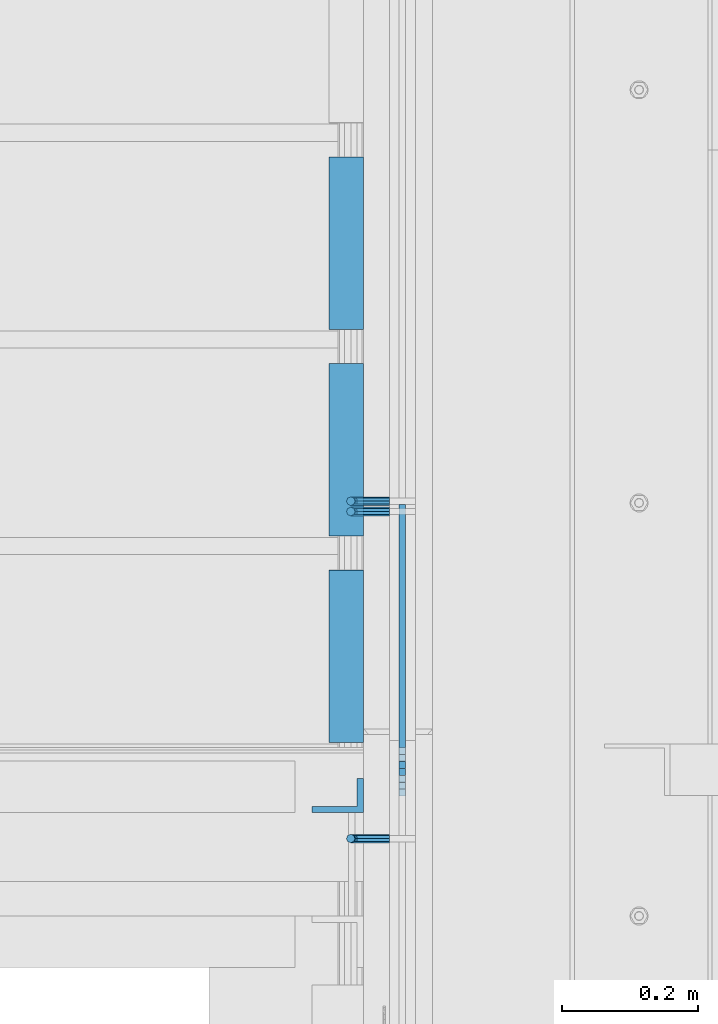
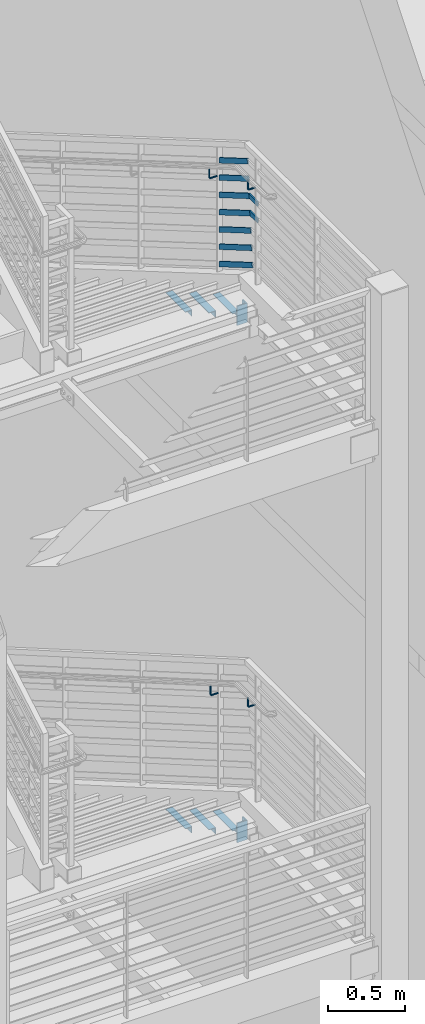
# One storey, part 867 of 1179: 14 beams, 7 members, 6 elements without a shape of their own.
"""IFC2X3 building model written with IfcOpenShell, lengths in millimetres."""

from ifc_helpers import new_model, si_unit, frame, origin_with_axes, place, context, subcontext, project, spatial, faceted_brep, material, type_object, element, aggregate, save


model = new_model("IFC2X3")

# Units and contexts
model_context = context("Model", 3, precision=1e-05, world=origin_with_axes())
body_context = subcontext(model_context, "Body", "Model", "MODEL_VIEW")
ifc_project = project(units=[si_unit("LENGTHUNIT", "METRE", prefix="MILLI"), si_unit("AREAUNIT", "SQUARE_METRE"), si_unit("VOLUMEUNIT", "CUBIC_METRE"), si_unit("MASSUNIT", "GRAM", prefix="KILO"), si_unit("TIMEUNIT", "SECOND"), si_unit("PLANEANGLEUNIT", "RADIAN"), si_unit("SOLIDANGLEUNIT", "STERADIAN"), si_unit("THERMODYNAMICTEMPERATUREUNIT", "DEGREE_CELSIUS"), si_unit("LUMINOUSINTENSITYUNIT", "LUMEN")], contexts=[model_context])

# Site, building, storey
site_placement = place(None, origin_with_axes())
site = spatial("IfcSite", under=ifc_project, at=site_placement, CompositionType="ELEMENT")
building_placement = place(site_placement, origin_with_axes())
building = spatial("IfcBuilding", under=site, at=building_placement, Name="Undefined", CompositionType="ELEMENT")
storey_placement = place(building_placement, origin_with_axes())
storey = spatial("IfcBuildingStorey", under=building, at=storey_placement, Name="Undefined", CompositionType="ELEMENT", Elevation=0.0)

# Assembly, beams
assembly_1_placement = place(storey_placement, origin_with_axes())
assembly_1 = element("IfcElementAssembly", 1, at=assembly_1_placement, inside=storey, Name="STRINGER", AssemblyPlace="NOTDEFINED", PredefinedType="RIGID_FRAME")
ifc_material = material(Name="STEEL/A36")
beam_type_1 = type_object("IfcBeamType", Name="L2X2X3/16", PredefinedType="NOTDEFINED")
beam_1_placement = place(assembly_1_placement, frame((-330.199999978706, 32145.9356228095, 5934.07499988955), z_axis=(-1.0, 0.0, 0.0), x_axis=(0.0, -1.0, 0.0)))
beam_1 = element("IfcBeam", 2, at=beam_1_placement, type_object=beam_type_1, material=ifc_material, Name="ANGLE", ObjectType="L2X2X3/16", context=body_context, shape_type="Brep", body=[
    faceted_brep([(0.0, 25.3999999999996, -25.4000000000015), (0.0, 25.3999999999996, 25.4000000000015), (254.0, 25.3999999999996, 25.4000000000001), (254.0, 25.3999999999996, -25.4000000000001), (0.0, 20.6374999999998, 25.4000000000015), (254.0, 20.6374999999998, 25.4000000000001), (0.0, 20.6374999999998, -20.6374999999971), (254.0, 20.6374999999998, -20.6374999999998), (0.0, -25.3999999999996, -20.6374999999971), (254.0, -25.3999999999996, -20.6374999999998), (0.0, -25.3999999999996, -25.4000000000015), (254.0, -25.3999999999996, -25.4000000000001)], [[[0, 1, 2, 3]], [[1, 4, 5, 2]], [[4, 6, 7, 5]], [[6, 8, 9, 7]], [[8, 10, 11, 9]], [[10, 0, 3, 11]], [[5, 7, 9, 11, 3, 2]], [[10, 8, 6, 4, 1, 0]]]),
])
beam_2_placement = place(assembly_1_placement, frame((-330.199999980762, 32450.7356227456, 5756.27499977985), z_axis=(-1.0, 0.0, 0.0), x_axis=(0.0, -1.0, 0.0)))
beam_2 = element("IfcBeam", 3, at=beam_2_placement, type_object=beam_type_1, material=ifc_material, Name="ANGLE", ObjectType="L2X2X3/16", context=body_context, shape_type="Brep", body=[
    faceted_brep([(0.0, 25.3999999999996, -25.4000000000015), (0.0, 25.3999999999996, 25.4000000000015), (254.0, 25.3999999999996, 25.4000000000001), (254.0, 25.3999999999996, -25.4000000000001), (0.0, 20.6374999999998, 25.4000000000015), (254.0, 20.6374999999998, 25.4000000000001), (0.0, 20.6374999999998, -20.6374999999971), (254.0, 20.6374999999998, -20.6374999999998), (0.0, -25.3999999999996, -20.6374999999971), (254.0, -25.3999999999996, -20.6374999999998), (0.0, -25.3999999999996, -25.4000000000015), (254.0, -25.3999999999996, -25.4000000000001)], [[[0, 1, 2, 3]], [[1, 4, 5, 2]], [[4, 6, 7, 5]], [[6, 8, 9, 7]], [[8, 10, 11, 9]], [[10, 0, 3, 11]], [[5, 7, 9, 11, 3, 2]], [[10, 8, 6, 4, 1, 0]]]),
])
beam_3_placement = place(assembly_1_placement, frame((-330.199999982818, 32755.5356226816, 5578.47499967015), z_axis=(-1.0, 0.0, 0.0), x_axis=(0.0, -1.0, 0.0)))
beam_3 = element("IfcBeam", 4, at=beam_3_placement, type_object=beam_type_1, material=ifc_material, Name="ANGLE", ObjectType="L2X2X3/16", context=body_context, shape_type="Brep", body=[
    faceted_brep([(0.0, 25.3999999999996, -25.4000000000015), (0.0, 25.3999999999996, 25.4000000000015), (254.0, 25.3999999999996, 25.4000000000001), (254.0, 25.3999999999996, -25.4000000000001), (0.0, 20.6374999999998, 25.4000000000015), (254.0, 20.6374999999998, 25.4000000000001), (0.0, 20.6374999999998, -20.6374999999971), (254.0, 20.6374999999998, -20.6374999999998), (0.0, -25.3999999999996, -20.6374999999971), (254.0, -25.3999999999996, -20.6374999999998), (0.0, -25.3999999999996, -25.4000000000015), (254.0, -25.3999999999996, -25.4000000000001)], [[[0, 1, 2, 3]], [[1, 4, 5, 2]], [[4, 6, 7, 5]], [[6, 8, 9, 7]], [[8, 10, 11, 9]], [[10, 0, 3, 11]], [[5, 7, 9, 11, 3, 2]], [[10, 8, 6, 4, 1, 0]]]),
])
aggregate(assembly_1, [beam_1, beam_2, beam_3])

assembly_2_placement = place(storey_placement, origin_with_axes())
assembly_2 = element("IfcElementAssembly", 5, at=assembly_2_placement, inside=storey, Name="STRINGER", AssemblyPlace="NOTDEFINED", PredefinedType="RIGID_FRAME")
beam_4_placement = place(assembly_2_placement, frame((-330.200000005577, 32145.8810167866, 1861.92102470219), z_axis=(-1.0, 0.0, 0.0), x_axis=(0.0, -1.0, 0.0)))
beam_4 = element("IfcBeam", 6, at=beam_4_placement, type_object=beam_type_1, material=ifc_material, Name="ANGLE", ObjectType="L2X2X3/16", context=body_context, shape_type="Brep", body=[
    faceted_brep([(0.0, 25.3999999999996, -25.4000000000015), (0.0, 25.3999999999996, 25.4000000000015), (254.0, 25.3999999999996, 25.4000000000001), (254.0, 25.3999999999996, -25.4000000000001), (0.0, 20.6374999999998, 25.4000000000015), (254.0, 20.6374999999998, 25.4000000000001), (0.0, 20.6374999999998, -20.6374999999971), (254.0, 20.6374999999998, -20.6374999999998), (0.0, -25.3999999999996, -20.6374999999971), (254.0, -25.3999999999996, -20.6374999999998), (0.0, -25.3999999999996, -25.4000000000015), (254.0, -25.3999999999996, -25.4000000000001)], [[[0, 1, 2, 3]], [[1, 4, 5, 2]], [[4, 6, 7, 5]], [[6, 8, 9, 7]], [[8, 10, 11, 9]], [[10, 0, 3, 11]], [[5, 7, 9, 11, 3, 2]], [[10, 8, 6, 4, 1, 0]]]),
])
beam_5_placement = place(assembly_2_placement, frame((-330.200000005532, 32450.6811705206, 1685.43913056534), z_axis=(-1.0, 0.0, 0.0), x_axis=(0.0, -1.0, 0.0)))
beam_5 = element("IfcBeam", 7, at=beam_5_placement, type_object=beam_type_1, material=ifc_material, Name="ANGLE", ObjectType="L2X2X3/16", context=body_context, shape_type="Brep", body=[
    faceted_brep([(0.0, 25.3999999999996, -25.4000000000015), (0.0, 25.3999999999996, 25.4000000000015), (254.0, 25.3999999999996, 25.4000000000001), (254.0, 25.3999999999996, -25.4000000000001), (0.0, 20.6374999999998, 25.4000000000015), (254.0, 20.6374999999998, 25.4000000000001), (0.0, 20.6374999999998, -20.6374999999971), (254.0, 20.6374999999998, -20.6374999999998), (0.0, -25.3999999999996, -20.6374999999971), (254.0, -25.3999999999996, -20.6374999999998), (0.0, -25.3999999999996, -25.4000000000015), (254.0, -25.3999999999996, -25.4000000000001)], [[[0, 1, 2, 3]], [[1, 4, 5, 2]], [[4, 6, 7, 5]], [[6, 8, 9, 7]], [[8, 10, 11, 9]], [[10, 0, 3, 11]], [[5, 7, 9, 11, 3, 2]], [[10, 8, 6, 4, 1, 0]]]),
])
beam_6_placement = place(assembly_2_placement, frame((-330.200000005492, 32755.4813242547, 1508.9572364282), z_axis=(-1.0, 0.0, 0.0), x_axis=(0.0, -1.0, 0.0)))
beam_6 = element("IfcBeam", 8, at=beam_6_placement, type_object=beam_type_1, material=ifc_material, Name="ANGLE", ObjectType="L2X2X3/16", context=body_context, shape_type="Brep", body=[
    faceted_brep([(0.0, 25.3999999999996, -25.4000000000015), (0.0, 25.3999999999996, 25.4000000000015), (254.0, 25.3999999999996, 25.4000000000001), (254.0, 25.3999999999996, -25.4000000000001), (0.0, 20.6374999999998, 25.4000000000015), (254.0, 20.6374999999998, 25.4000000000001), (0.0, 20.6374999999998, -20.6374999999971), (254.0, 20.6374999999998, -20.6374999999998), (0.0, -25.3999999999996, -20.6374999999971), (254.0, -25.3999999999996, -20.6374999999998), (0.0, -25.3999999999996, -25.4000000000015), (254.0, -25.3999999999996, -25.4000000000001)], [[[0, 1, 2, 3]], [[1, 4, 5, 2]], [[4, 6, 7, 5]], [[6, 8, 9, 7]], [[8, 10, 11, 9]], [[10, 0, 3, 11]], [[5, 7, 9, 11, 3, 2]], [[10, 8, 6, 4, 1, 0]]]),
])
aggregate(assembly_2, [beam_4, beam_5, beam_6])

# Assembly, beam
assembly_3_placement = place(storey_placement, origin_with_axes())
assembly_3 = element("IfcElementAssembly", 9, at=assembly_3_placement, inside=storey, Name="GUARDRAIL", AssemblyPlace="NOTDEFINED", PredefinedType="RIGID_FRAME")
beam_type_2 = type_object("IfcBeamType", PredefinedType="NOTDEFINED")
beam_7_placement = place(assembly_3_placement, frame((-266.699997778982, 31749.998309175, 2936.92791904201), z_axis=(0.0, 0.0, 1.0), x_axis=(-1.0, 0.0, 0.0)))
beam_7 = element("IfcBeam", 10, at=beam_7_placement, type_object=beam_type_2, material=ifc_material, Name="BRACKET", context=body_context, shape_type="Brep", body=[
    faceted_brep([(0.0, -4.49012806053361, 4.49012806053452), (0.0, 0.0, 6.34999999999991), (0.0, 4.49012806053361, 4.49012806053452), (0.0, 6.34999999999854, 0.0), (0.0, 4.49012806053361, -4.49012806053452), (0.0, 0.0, -6.34999999999991), (0.0, -4.49012806053361, -4.49012806053452), (0.0, -6.34999999999854, 0.0), (44.4500031699827, 0.0, -6.34999999999991), (44.4500031699827, -4.49012806053361, -4.49012806053452), (44.4500031699827, -6.34999999999854, 2.19733919948339e-09), (44.4500031699827, -4.49012806053361, 4.49012806053452), (44.4500031699827, 0.0, 6.34999999999991), (44.4500031699827, 4.49012806053361, 4.49012806053452), (44.4500031699827, 6.34999999999854, 0.0), (44.4500031699827, 4.49012806053361, -4.49012806053452), (53.0450671075391, 4.4901280570557, -2.18708762112465), (53.97500307462, -4.32919478043914e-09, -3.79778396764459), (53.0450671022344, -4.49012806401151, -2.1870876194389), (50.8000030708674, -6.35000000142099, 1.70147734757802), (48.5549390416977, -4.4901280599006, 5.59004231389645), (47.6250030746168, 1.48793333210051e-09, 7.20073866041594), (48.5549390470023, 4.49012806117025, 5.5900423122107), (50.8000030783693, 6.34999999857973, 1.70147734519378), (55.4485256393576, 6.34999999469437, 6.34999990618098), (59.337090604122, 4.49012805180246, 4.10493587545716), (51.5599606707875, 4.49012805866005, 8.59506393599531), (49.9492643188311, -4.54747350886464e-10, 9.52499990463002), (51.5599606615996, -4.4901280624108, 8.59506393379797), (55.4485256263639, -6.35000000530636, 6.34999990307369), (59.337090594938, -4.49012806926839, 4.10493587326664), (60.9477869468905, -1.0153598850593e-08, 3.17499990462466), (61.6401310450869, 4.49012804462109, 12.6999998130159), (63.5000029792477, -1.81098585017025e-08, 12.6999998092651), (57.1500029867496, 6.3499999893902, 12.6999998145698), (52.6598749240178, 4.49012805522943, 12.6999998130159), (50.8000029792477, -3.10683390125632e-09, 12.6999998092651), (52.6598749134085, -4.49012806583778, 12.6999998055144), (57.1500029739432, -6.35000001061053, 12.6999998039605), (61.6401310344776, -4.49012807644976, 12.6999998055144), (63.5000029792478, -6.94672053214163e-08, 76.1999999999989), (61.6401310356729, -4.49012812829824, 76.1999999999989), (57.1500029739432, -6.3500000636559, 76.1999999999989), (52.6598749146037, -4.49012812008004, 76.1999999999989), (50.8000029792478, -5.78438630327582e-08, 76.1999999999989), (52.6598749228227, 4.49012800098717, 76.1999999999989), (57.1500029850595, 6.34999993634483, 76.1999999999989), (61.6401310438919, 4.49012799276898, 76.1999999999989)], [[[0, 1, 2, 3, 4, 5, 6, 7]], [[6, 5, 8, 9]], [[7, 6, 9, 10]], [[0, 7, 10, 11]], [[1, 0, 11, 12]], [[2, 1, 12, 13]], [[3, 2, 13, 14]], [[4, 3, 14, 15]], [[5, 4, 15, 8]], [[8, 15, 16, 17]], [[9, 8, 17, 18]], [[10, 9, 18, 19]], [[11, 10, 19, 20]], [[12, 11, 20, 21]], [[13, 12, 21, 22]], [[14, 13, 22, 23]], [[15, 14, 23, 16]], [[23, 24, 25, 16]], [[22, 26, 24, 23]], [[21, 27, 26, 22]], [[20, 28, 27, 21]], [[19, 29, 28, 20]], [[18, 30, 29, 19]], [[17, 31, 30, 18]], [[16, 25, 31, 17]], [[25, 32, 33, 31]], [[24, 34, 32, 25]], [[26, 35, 34, 24]], [[27, 36, 35, 26]], [[28, 37, 36, 27]], [[29, 38, 37, 28]], [[30, 39, 38, 29]], [[31, 33, 39, 30]], [[39, 33, 40, 41]], [[38, 39, 41, 42]], [[37, 38, 42, 43]], [[36, 37, 43, 44]], [[35, 36, 44, 45]], [[34, 35, 45, 46]], [[32, 34, 46, 47]], [[33, 32, 47, 40]], [[46, 45, 44, 43, 42, 41, 40, 47]]]),
])

# Assembly, beams
assembly_4_placement = place(storey_placement, origin_with_axes())
assembly_4 = element("IfcElementAssembly", 11, at=assembly_4_placement, inside=storey, Name="GUARDRAIL", AssemblyPlace="NOTDEFINED", PredefinedType="RIGID_FRAME")
beam_8_placement = place(assembly_4_placement, frame((-266.699997779377, 31749.9983091741, 7010.39999999813), z_axis=(0.0, 0.0, 1.0), x_axis=(-1.0, 0.0, 0.0)))
beam_8 = element("IfcBeam", 12, at=beam_8_placement, type_object=beam_type_2, material=ifc_material, Name="BRACKET", context=body_context, shape_type="Brep", body=[
    faceted_brep([(0.0, -4.49012806053361, 4.49012806053452), (0.0, 0.0, 6.34999999999991), (0.0, 4.49012806053361, 4.49012806053452), (0.0, 6.34999999999854, 0.0), (0.0, 4.49012806053361, -4.49012806053452), (0.0, 0.0, -6.34999999999991), (0.0, -4.49012806053361, -4.49012806053452), (0.0, -6.34999999999854, 0.0), (44.4500031699827, 0.0, -6.34999999999991), (44.4500031699827, -4.49012806053361, -4.49012806053452), (44.4500031699827, -6.34999999999854, 2.19733919948339e-09), (44.4500031699827, -4.49012806053361, 4.49012806053452), (44.4500031699827, 0.0, 6.34999999999991), (44.4500031699827, 4.49012806053361, 4.49012806053452), (44.4500031699827, 6.34999999999854, 0.0), (44.4500031699827, 4.49012806053361, -4.49012806053452), (53.0450671075391, 4.4901280570557, -2.18708762112465), (53.97500307462, -4.32919478043914e-09, -3.79778396764459), (53.0450671022344, -4.49012806401151, -2.1870876194389), (50.8000030708674, -6.35000000142099, 1.70147734757802), (48.5549390416977, -4.4901280599006, 5.59004231389645), (47.6250030746168, 1.48793333210051e-09, 7.20073866041594), (48.5549390470023, 4.49012806117025, 5.5900423122107), (50.8000030783693, 6.34999999857973, 1.70147734519378), (55.4485256393576, 6.34999999469437, 6.34999990618098), (59.337090604122, 4.49012805180246, 4.10493587545716), (51.5599606707875, 4.49012805866005, 8.59506393599531), (49.9492643188311, -4.54747350886464e-10, 9.52499990463002), (51.5599606615996, -4.4901280624108, 8.59506393379797), (55.4485256263639, -6.35000000530636, 6.34999990307369), (59.337090594938, -4.49012806926839, 4.10493587326664), (60.9477869468905, -1.0153598850593e-08, 3.17499990462466), (61.6401310450869, 4.49012804462109, 12.6999998130159), (63.5000029792477, -1.81098585017025e-08, 12.6999998092651), (57.1500029867496, 6.3499999893902, 12.6999998145698), (52.6598749240178, 4.49012805522943, 12.6999998130159), (50.8000029792477, -3.10683390125632e-09, 12.6999998092651), (52.6598749134085, -4.49012806583778, 12.6999998055144), (57.1500029739432, -6.35000001061053, 12.6999998039605), (61.6401310344776, -4.49012807644976, 12.6999998055144), (63.5000029792478, -6.94672053214163e-08, 76.1999999999989), (61.6401310356729, -4.49012812829824, 76.1999999999989), (57.1500029739432, -6.3500000636559, 76.1999999999989), (52.6598749146037, -4.49012812008004, 76.1999999999989), (50.8000029792478, -5.78438630327582e-08, 76.1999999999989), (52.6598749228227, 4.49012800098717, 76.1999999999989), (57.1500029850595, 6.34999993634483, 76.1999999999989), (61.6401310438919, 4.49012799276898, 76.1999999999989)], [[[0, 1, 2, 3, 4, 5, 6, 7]], [[6, 5, 8, 9]], [[7, 6, 9, 10]], [[0, 7, 10, 11]], [[1, 0, 11, 12]], [[2, 1, 12, 13]], [[3, 2, 13, 14]], [[4, 3, 14, 15]], [[5, 4, 15, 8]], [[8, 15, 16, 17]], [[9, 8, 17, 18]], [[10, 9, 18, 19]], [[11, 10, 19, 20]], [[12, 11, 20, 21]], [[13, 12, 21, 22]], [[14, 13, 22, 23]], [[15, 14, 23, 16]], [[23, 24, 25, 16]], [[22, 26, 24, 23]], [[21, 27, 26, 22]], [[20, 28, 27, 21]], [[19, 29, 28, 20]], [[18, 30, 29, 19]], [[17, 31, 30, 18]], [[16, 25, 31, 17]], [[25, 32, 33, 31]], [[24, 34, 32, 25]], [[26, 35, 34, 24]], [[27, 36, 35, 26]], [[28, 37, 36, 27]], [[29, 38, 37, 28]], [[30, 39, 38, 29]], [[31, 33, 39, 30]], [[39, 33, 40, 41]], [[38, 39, 41, 42]], [[37, 38, 42, 43]], [[36, 37, 43, 44]], [[35, 36, 44, 45]], [[34, 35, 45, 46]], [[32, 34, 46, 47]], [[33, 32, 47, 40]], [[46, 45, 44, 43, 42, 41, 40, 47]]]),
])
beam_9_placement = place(assembly_4_placement, frame((-266.699999255495, 32247.8389866369, 6798.481336689), z_axis=(0.0, 0.0, 1.0), x_axis=(-1.0, 0.0, 0.0)))
beam_9 = element("IfcBeam", 13, at=beam_9_placement, type_object=beam_type_2, material=ifc_material, Name="BRACKET", context=body_context, shape_type="Brep", body=[
    faceted_brep([(0.0, -4.49012806053361, 4.49012806053452), (0.0, 0.0, 6.34999999999991), (0.0, 4.49012806053361, 4.49012806053452), (0.0, 6.34999999999854, 0.0), (0.0, 4.49012806053361, -4.49012806053452), (0.0, 0.0, -6.34999999999991), (0.0, -4.49012806053361, -4.49012806053452), (0.0, -6.34999999999854, 0.0), (44.4500031699827, 0.0, -6.34999999999991), (44.4500031699827, -4.49012806053361, -4.49012806053452), (44.4500031699827, -6.34999999999854, 2.19733919948339e-09), (44.4500031699827, -4.49012806053361, 4.49012806053452), (44.4500031699827, 0.0, 6.34999999999991), (44.4500031699827, 4.49012806053361, 4.49012806053452), (44.4500031699827, 6.34999999999854, 0.0), (44.4500031699827, 4.49012806053361, -4.49012806053452), (53.0450671075391, 4.4901280570557, -2.18708762112465), (53.97500307462, -4.32919478043914e-09, -3.79778396764459), (53.0450671022344, -4.49012806401151, -2.1870876194389), (50.8000030708674, -6.35000000142099, 1.70147734757802), (48.5549390416977, -4.4901280599006, 5.59004231389645), (47.6250030746168, 1.48793333210051e-09, 7.20073866041594), (48.5549390470023, 4.49012806117025, 5.5900423122107), (50.8000030783693, 6.34999999857973, 1.70147734519378), (55.4485256393576, 6.34999999469437, 6.34999990618098), (59.337090604122, 4.49012805180246, 4.10493587545716), (51.5599606707875, 4.49012805866005, 8.59506393599531), (49.9492643188311, -4.54747350886464e-10, 9.52499990463002), (51.5599606615996, -4.4901280624108, 8.59506393379797), (55.4485256263639, -6.35000000530636, 6.34999990307369), (59.337090594938, -4.49012806926839, 4.10493587326664), (60.9477869468905, -1.0153598850593e-08, 3.17499990462466), (61.6401310450869, 4.49012804462109, 12.6999998130159), (63.5000029792477, -1.81098585017025e-08, 12.6999998092651), (57.1500029867496, 6.3499999893902, 12.6999998145698), (52.6598749240178, 4.49012805522943, 12.6999998130159), (50.8000029792477, -3.10683390125632e-09, 12.6999998092651), (52.6598749134085, -4.49012806583778, 12.6999998055144), (57.1500029739432, -6.35000001061053, 12.6999998039605), (61.6401310344776, -4.49012807644976, 12.6999998055144), (63.5000029792478, -6.94672053214163e-08, 76.1999999999989), (61.6401294880352, -4.49012904147821, 73.5807586715764), (57.1500014109847, -6.35000090467656, 72.4958334126568), (52.6598733669657, -4.49012891602615, 73.5807587357776), (50.8000029792478, -5.78438630327582e-08, 76.1999999999989), (52.6598734909962, 4.49012713825505, 78.8192414384375), (57.1500015765077, 6.34999900287221, 79.9041666981866), (61.6401296120657, 4.49012701564061, 78.8192413758952)], [[[0, 1, 2, 3, 4, 5, 6, 7]], [[6, 5, 8, 9]], [[7, 6, 9, 10]], [[0, 7, 10, 11]], [[1, 0, 11, 12]], [[2, 1, 12, 13]], [[3, 2, 13, 14]], [[4, 3, 14, 15]], [[5, 4, 15, 8]], [[8, 15, 16, 17]], [[9, 8, 17, 18]], [[10, 9, 18, 19]], [[11, 10, 19, 20]], [[12, 11, 20, 21]], [[13, 12, 21, 22]], [[14, 13, 22, 23]], [[15, 14, 23, 16]], [[23, 24, 25, 16]], [[22, 26, 24, 23]], [[21, 27, 26, 22]], [[20, 28, 27, 21]], [[19, 29, 28, 20]], [[18, 30, 29, 19]], [[17, 31, 30, 18]], [[16, 25, 31, 17]], [[25, 32, 33, 31]], [[24, 34, 32, 25]], [[26, 35, 34, 24]], [[27, 36, 35, 26]], [[28, 37, 36, 27]], [[29, 38, 37, 28]], [[30, 39, 38, 29]], [[31, 33, 39, 30]], [[39, 33, 40, 41]], [[38, 39, 41, 42]], [[37, 38, 42, 43]], [[36, 37, 43, 44]], [[35, 36, 44, 45]], [[34, 35, 45, 46]], [[32, 34, 46, 47]], [[33, 32, 47, 40]], [[46, 45, 44, 43, 42, 41, 40, 47]]]),
])

# Beam
beam_10_placement = place(assembly_3_placement, frame((-266.699999255495, 32232.6000011131, 2735.42303088814), z_axis=(0.0, 0.0, 1.0), x_axis=(-1.0, 0.0, 0.0)))
beam_10 = element("IfcBeam", 14, at=beam_10_placement, type_object=beam_type_2, material=ifc_material, Name="BRACKET", context=body_context, shape_type="Brep", body=[
    faceted_brep([(0.0, -4.49012806053361, 4.49012806053452), (0.0, 0.0, 6.34999999999991), (0.0, 4.49012806053361, 4.49012806053452), (0.0, 6.34999999999854, 0.0), (0.0, 4.49012806053361, -4.49012806053452), (0.0, 0.0, -6.34999999999991), (0.0, -4.49012806053361, -4.49012806053452), (0.0, -6.34999999999854, 0.0), (44.4500031699827, 0.0, -6.34999999999991), (44.4500031699827, -4.49012806053361, -4.49012806053452), (44.4500031699827, -6.34999999999854, 2.19733919948339e-09), (44.4500031699827, -4.49012806053361, 4.49012806053452), (44.4500031699827, 0.0, 6.34999999999991), (44.4500031699827, 4.49012806053361, 4.49012806053452), (44.4500031699827, 6.34999999999854, 0.0), (44.4500031699827, 4.49012806053361, -4.49012806053452), (53.0450671075391, 4.4901280570557, -2.18708762112465), (53.97500307462, -4.32919478043914e-09, -3.79778396764459), (53.0450671022344, -4.49012806401151, -2.1870876194389), (50.8000030708674, -6.35000000142099, 1.70147734757802), (48.5549390416977, -4.4901280599006, 5.59004231389645), (47.6250030746168, 1.48793333210051e-09, 7.20073866041594), (48.5549390470023, 4.49012806117025, 5.5900423122107), (50.8000030783693, 6.34999999857973, 1.70147734519378), (55.4485256393576, 6.34999999469437, 6.34999990618098), (59.337090604122, 4.49012805180246, 4.10493587545716), (51.5599606707875, 4.49012805866005, 8.59506393599531), (49.9492643188311, -4.54747350886464e-10, 9.52499990463002), (51.5599606615996, -4.4901280624108, 8.59506393379797), (55.4485256263639, -6.35000000530636, 6.34999990307369), (59.337090594938, -4.49012806926839, 4.10493587326664), (60.9477869468905, -1.0153598850593e-08, 3.17499990462466), (61.6401310450869, 4.49012804462109, 12.6999998130159), (63.5000029792477, -1.81098585017025e-08, 12.6999998092651), (57.1500029867496, 6.3499999893902, 12.6999998145698), (52.6598749240178, 4.49012805522943, 12.6999998130159), (50.8000029792477, -3.10683390125632e-09, 12.6999998092651), (52.6598749134085, -4.49012806583778, 12.6999998055144), (57.1500029739432, -6.35000001061053, 12.6999998039605), (61.6401310344776, -4.49012807644976, 12.6999998055144), (63.5000029792478, -6.94672053214163e-08, 76.1999999999989), (61.6401296086745, -4.49012715444769, 73.6001774342253), (57.1500015634042, -6.3499991642384, 72.5232956440923), (52.6598734876054, -4.49012727027366, 73.6001773671605), (50.8000029792478, -5.78438630327582e-08, 76.1999999999989), (52.6598733730815, 4.4901289120171, 78.79982245163), (57.150001410549, 6.35000092050541, 79.8767042410086), (61.6401294941506, 4.49012902523828, 78.7998225171859)], [[[0, 1, 2, 3, 4, 5, 6, 7]], [[6, 5, 8, 9]], [[7, 6, 9, 10]], [[0, 7, 10, 11]], [[1, 0, 11, 12]], [[2, 1, 12, 13]], [[3, 2, 13, 14]], [[4, 3, 14, 15]], [[5, 4, 15, 8]], [[8, 15, 16, 17]], [[9, 8, 17, 18]], [[10, 9, 18, 19]], [[11, 10, 19, 20]], [[12, 11, 20, 21]], [[13, 12, 21, 22]], [[14, 13, 22, 23]], [[15, 14, 23, 16]], [[23, 24, 25, 16]], [[22, 26, 24, 23]], [[21, 27, 26, 22]], [[20, 28, 27, 21]], [[19, 29, 28, 20]], [[18, 30, 29, 19]], [[17, 31, 30, 18]], [[16, 25, 31, 17]], [[25, 32, 33, 31]], [[24, 34, 32, 25]], [[26, 35, 34, 24]], [[27, 36, 35, 26]], [[28, 37, 36, 27]], [[29, 38, 37, 28]], [[30, 39, 38, 29]], [[31, 33, 39, 30]], [[39, 33, 40, 41]], [[38, 39, 41, 42]], [[37, 38, 42, 43]], [[36, 37, 43, 44]], [[35, 36, 44, 45]], [[34, 35, 45, 46]], [[32, 34, 46, 47]], [[33, 32, 47, 40]], [[46, 45, 44, 43, 42, 41, 40, 47]]]),
])

aggregate(assembly_3, [beam_7, beam_10])

beam_type_3 = type_object("IfcBeamType", PredefinedType="NOTDEFINED")
beam_11_placement = place(assembly_4_placement, frame((-247.65000070544, 31819.2355629775, 6740.52500013339), z_axis=(0.0, 0.0, 1.0), x_axis=(0.0, -1.0, 0.0)))
beam_11 = element("IfcBeam", 15, at=beam_11_placement, type_object=beam_type_3, material=ifc_material, Name="PLATE", context=body_context, shape_type="Brep", body=[
    faceted_brep([(-24.1327845652449, 4.76249999999999, -19.0500000000002), (-34.4330868470606, 4.76249999999999, 19.0500000000002), (64.4747538053671, 4.76249999999999, 19.0500000000002), (64.4747538053671, 4.76249999999999, -19.0500000000002), (-34.4330868470606, -4.76249999999999, 19.0500000000002), (64.4747538053671, -4.76249999999999, 19.0500000000002), (-24.1327845652449, -4.76249999999999, -19.0500000000002), (64.4747538053671, -4.76249999999999, -19.0500000000002)], [[[0, 1, 2, 3]], [[1, 4, 5, 2]], [[4, 6, 7, 5]], [[6, 0, 3, 7]], [[5, 7, 3, 2]], [[6, 4, 1, 0]]]),
])

beam_12_placement = place(assembly_4_placement, frame((-247.650000708665, 31830.1212773443, 6870.70000008446), z_axis=(0.0, 0.0, 1.0), x_axis=(0.0, -1.0, 0.0)))
beam_12 = element("IfcBeam", 16, at=beam_12_placement, type_object=beam_type_3, material=ifc_material, Name="PLATE", context=body_context, shape_type="Brep", body=[
    faceted_brep([(-23.5473724373842, 4.76249999999999, -19.0500000000002), (-33.8476747191962, 4.76249999999999, 19.0500000000002), (75.360468172159, 4.76249999999999, 19.0500000000002), (75.360468172159, 4.76249999999999, -19.0500000000002), (-33.8476747191962, -4.76249999999999, 19.0500000000002), (75.360468172159, -4.76249999999999, 19.0500000000002), (-23.5473724373842, -4.76249999999999, -19.0500000000002), (75.360468172159, -4.76249999999999, -19.0500000000002)], [[[0, 1, 2, 3]], [[1, 4, 5, 2]], [[4, 6, 7, 5]], [[6, 0, 3, 7]], [[5, 7, 3, 2]], [[6, 4, 1, 0]]]),
])

# Member
member_type = type_object("IfcMemberType", PredefinedType="NOTDEFINED")
member_1_placement = place(assembly_4_placement, frame((-247.650000724199, 32238.2402427242, 6104.63678713089), z_axis=(0.0, 0.503871025834968, 0.863778900717086), x_axis=(0.0, -0.863778900717086, 0.503871025834967)))
member_1 = element("IfcMember", 17, at=member_1_placement, type_object=member_type, material=ifc_material, Name="PLATE", context=body_context, shape_type="Brep", body=[
    faceted_brep([(-16.7114354625264, 4.76250000000005, -19.0500000000065), (5.51356370517169, 4.76250000000005, 19.0500000000338), (492.106535844097, 4.76249999999999, 19.0499999995518), (481.806233490155, 4.76249999999999, -19.0500000004213), (5.51356370517169, -4.76250000000005, 19.0500000000338), (492.106535844097, -4.76249999999999, 19.0499999995518), (-16.7114354625264, -4.76250000000005, -19.0500000000065), (481.806233490155, -4.76249999999999, -19.0500000004213)], [[[0, 1, 2, 3]], [[1, 4, 5, 2]], [[4, 6, 7, 5]], [[6, 0, 3, 7]], [[5, 7, 3, 2]], [[6, 4, 1, 0]]]),
])

member_2_placement = place(assembly_4_placement, frame((-247.650000724254, 32238.2402427201, 6240.82029672938), z_axis=(0.0, 0.503871025834968, 0.863778900717086), x_axis=(0.0, -0.863778900717086, 0.503871025834967)))
member_2 = element("IfcMember", 18, at=member_2_placement, type_object=member_type, material=ifc_material, Name="PLATE", context=body_context, shape_type="Brep", body=[
    faceted_brep([(-16.7114354625264, 4.76250000000005, -19.0500000000065), (5.51356370517169, 4.76250000000005, 19.0500000000338), (480.181838249071, 4.76249999999999, 19.0499999995627), (469.881535934601, 4.76249999999999, -19.0500000004104), (5.51356370517169, -4.76250000000005, 19.0500000000338), (480.181838249071, -4.76249999999999, 19.0499999995627), (-16.7114354625264, -4.76250000000005, -19.0500000000065), (469.881535934601, -4.76249999999999, -19.0500000004104)], [[[0, 1, 2, 3]], [[1, 4, 5, 2]], [[4, 6, 7, 5]], [[6, 0, 3, 7]], [[5, 7, 3, 2]], [[6, 4, 1, 0]]]),
])

member_3_placement = place(assembly_4_placement, frame((-247.65000072431, 32238.2402427158, 6377.00380632813), z_axis=(0.0, 0.503871025834968, 0.863778900717086), x_axis=(0.0, -0.863778900717086, 0.503871025834967)))
member_3 = element("IfcMember", 19, at=member_3_placement, type_object=member_type, material=ifc_material, Name="PLATE", context=body_context, shape_type="Brep", body=[
    faceted_brep([(-16.7114354625264, 4.76250000000005, -19.0500000000065), (5.51356370517169, 4.76250000000005, 19.0500000000338), (468.257140399946, 4.76249999999999, 19.0499999995736), (457.956838046011, 4.76249999999999, -19.0500000003995), (5.51356370517169, -4.76250000000005, 19.0500000000338), (468.257140399946, -4.76249999999999, 19.0499999995736), (-16.7114354625264, -4.76250000000005, -19.0500000000065), (457.956838046011, -4.76249999999999, -19.0500000003995)], [[[0, 1, 2, 3]], [[1, 4, 5, 2]], [[4, 6, 7, 5]], [[6, 0, 3, 7]], [[5, 7, 3, 2]], [[6, 4, 1, 0]]]),
])

member_4_placement = place(assembly_4_placement, frame((-247.65000072437, 32238.2402427116, 6513.18731592635), z_axis=(0.0, 0.503871025834968, 0.863778900717086), x_axis=(0.0, -0.863778900717086, 0.503871025834967)))
member_4 = element("IfcMember", 20, at=member_4_placement, type_object=member_type, material=ifc_material, Name="PLATE", context=body_context, shape_type="Brep", body=[
    faceted_brep([(-16.7114354625264, 4.76250000000005, -19.0500000000065), (5.51356370517169, 4.76250000000005, 19.0500000000338), (456.332442946936, 4.76249999999999, 19.0499999995882), (446.032140643139, 4.76249999999999, -19.0500000003849), (5.51356370517169, -4.76250000000005, 19.0500000000338), (456.332442946936, -4.76249999999999, 19.0499999995882), (-16.7114354625264, -4.76250000000005, -19.0500000000065), (446.032140643139, -4.76249999999999, -19.0500000003849)], [[[0, 1, 2, 3]], [[1, 4, 5, 2]], [[4, 6, 7, 5]], [[6, 0, 3, 7]], [[5, 7, 3, 2]], [[6, 4, 1, 0]]]),
])

member_5_placement = place(assembly_4_placement, frame((-247.650000724433, 32238.2402427073, 6649.37082552425), z_axis=(0.0, 0.503871025834968, 0.863778900717086), x_axis=(0.0, -0.863778900717086, 0.503871025834967)))
member_5 = element("IfcMember", 21, at=member_5_placement, type_object=member_type, material=ifc_material, Name="PLATE", context=body_context, shape_type="Brep", body=[
    faceted_brep([(-16.7114354625264, 4.76250000000005, -19.0500000000065), (5.51356370517169, 4.76250000000005, 19.0500000000338), (444.407745278717, 4.76249999999999, 19.0499999995955), (434.107442974921, 4.76249999999999, -19.0500000003776), (5.51356370517169, -4.76250000000005, 19.0500000000338), (444.407745278717, -4.76249999999999, 19.0499999995955), (-16.7114354625264, -4.76250000000005, -19.0500000000065), (434.107442974921, -4.76249999999999, -19.0500000003776)], [[[0, 1, 2, 3]], [[1, 4, 5, 2]], [[4, 6, 7, 5]], [[6, 0, 3, 7]], [[5, 7, 3, 2]], [[6, 4, 1, 0]]]),
])

member_6_placement = place(assembly_4_placement, frame((-247.650000724499, 32238.2402427031, 6785.55433512273), z_axis=(0.0, 0.503871025834968, 0.863778900717086), x_axis=(0.0, -0.863778900717086, 0.503871025834967)))
member_6 = element("IfcMember", 22, at=member_6_placement, type_object=member_type, material=ifc_material, Name="PLATE", context=body_context, shape_type="Brep", body=[
    faceted_brep([(-16.7114354625264, 4.76250000000005, -19.0500000000065), (5.51356370517169, 4.76250000000005, 19.0500000000338), (432.48304760941, 4.76249999999999, 19.04999999961), (422.182745305614, 4.76249999999999, -19.0500000003594), (5.51356370517169, -4.76250000000005, 19.0500000000338), (432.48304760941, -4.76249999999999, 19.04999999961), (-16.7114354625264, -4.76250000000005, -19.0500000000065), (422.182745305614, -4.76249999999999, -19.0500000003594)], [[[0, 1, 2, 3]], [[1, 4, 5, 2]], [[4, 6, 7, 5]], [[6, 0, 3, 7]], [[5, 7, 3, 2]], [[6, 4, 1, 0]]]),
])

member_7_placement = place(assembly_4_placement, frame((-247.650000724804, 32238.2402427265, 6921.73784522752), z_axis=(0.0, 0.503871025834968, 0.863778900717086), x_axis=(0.0, -0.863778900717086, 0.503871025834967)))
member_7 = element("IfcMember", 23, at=member_7_placement, type_object=member_type, material=ifc_material, Name="PLATE", context=body_context, shape_type="Brep", body=[
    faceted_brep([(-16.7114354625264, 4.76250000000005, -19.0500000000065), (5.51356370517169, 4.76250000000005, 19.0500000000338), (420.558348944334, 4.76249999999999, 19.0499999996246), (410.258046640534, 4.76249999999999, -19.0500000003522), (5.51356370517169, -4.76250000000005, 19.0500000000338), (420.558348944334, -4.76249999999999, 19.0499999996246), (-16.7114354625264, -4.76250000000005, -19.0500000000065), (410.258046640534, -4.76249999999999, -19.0500000003522)], [[[0, 1, 2, 3]], [[1, 4, 5, 2]], [[4, 6, 7, 5]], [[6, 0, 3, 7]], [[5, 7, 3, 2]], [[6, 4, 1, 0]]]),
])

aggregate(assembly_4, [beam_8, beam_9, member_1, member_2, member_3, member_4, member_5, member_6, member_7, beam_11, beam_12])

# Assembly, beam
assembly_5_placement = place(storey_placement, origin_with_axes())
assembly_5 = element("IfcElementAssembly", 24, at=assembly_5_placement, inside=storey, Name="ANGLE", AssemblyPlace="NOTDEFINED", PredefinedType="RIGID_FRAME")
beam_type_4 = type_object("IfcBeamType", Name="L3X2X3/8", PredefinedType="NOTDEFINED")
beam_13_placement = place(assembly_5_placement, frame((-342.90000001051, 31813.4999999734, 6089.65), z_axis=(-1.0, 0.0, 0.0), x_axis=(0.0, 0.0, -1.0)))
beam_13 = element("IfcBeam", 25, at=beam_13_placement, type_object=beam_type_4, material=ifc_material, Name="ANGLE", ObjectType="L3X2X3/8", context=body_context, shape_type="Brep", body=[
    faceted_brep([(0.0, 25.4000000000015, -38.0999999999999), (0.0, 25.4000000000015, 38.0999999999999), (152.4, 25.4000000000015, 38.0999999999999), (152.4, 25.4000000000015, -38.0999999999999), (0.0, 15.875, 38.0999999999999), (152.4, 15.875, 38.0999999999999), (0.0, 15.875, -28.575), (152.4, 15.875, -28.575), (0.0, -25.4000000000015, -28.575), (152.4, -25.4000000000015, -28.575), (0.0, -25.4000000000015, -38.0999999999999), (152.4, -25.4000000000015, -38.0999999999999)], [[[0, 1, 2, 3]], [[1, 4, 5, 2]], [[4, 6, 7, 5]], [[6, 8, 9, 7]], [[8, 10, 11, 9]], [[10, 0, 3, 11]], [[5, 7, 9, 11, 3, 2]], [[10, 8, 6, 4, 1, 0]]]),
])
aggregate(assembly_5, [beam_13])

assembly_6_placement = place(storey_placement, origin_with_axes())
assembly_6 = element("IfcElementAssembly", 26, at=assembly_6_placement, inside=storey, Name="ANGLE", AssemblyPlace="NOTDEFINED", PredefinedType="RIGID_FRAME")
beam_14_placement = place(assembly_6_placement, frame((-342.90000001051, 31813.4999999734, 2016.125), z_axis=(-1.0, 0.0, 0.0), x_axis=(0.0, 0.0, -1.0)))
beam_14 = element("IfcBeam", 27, at=beam_14_placement, type_object=beam_type_4, material=ifc_material, Name="ANGLE", ObjectType="L3X2X3/8", context=body_context, shape_type="Brep", body=[
    faceted_brep([(0.0, 25.4000000000015, -38.0999999999999), (0.0, 25.4000000000015, 38.0999999999999), (152.4, 25.4000000000015, 38.0999999999999), (152.4, 25.4000000000015, -38.0999999999999), (0.0, 15.875, 38.0999999999999), (152.4, 15.875, 38.0999999999999), (0.0, 15.875, -28.575), (152.4, 15.875, -28.575), (0.0, -25.4000000000015, -28.575), (152.4, -25.4000000000015, -28.575), (0.0, -25.4000000000015, -38.0999999999999), (152.4, -25.4000000000015, -38.0999999999999)], [[[0, 1, 2, 3]], [[1, 4, 5, 2]], [[4, 6, 7, 5]], [[6, 8, 9, 7]], [[8, 10, 11, 9]], [[10, 0, 3, 11]], [[5, 7, 9, 11, 3, 2]], [[10, 8, 6, 4, 1, 0]]]),
])
aggregate(assembly_6, [beam_14])

save(model, "model.ifc")
